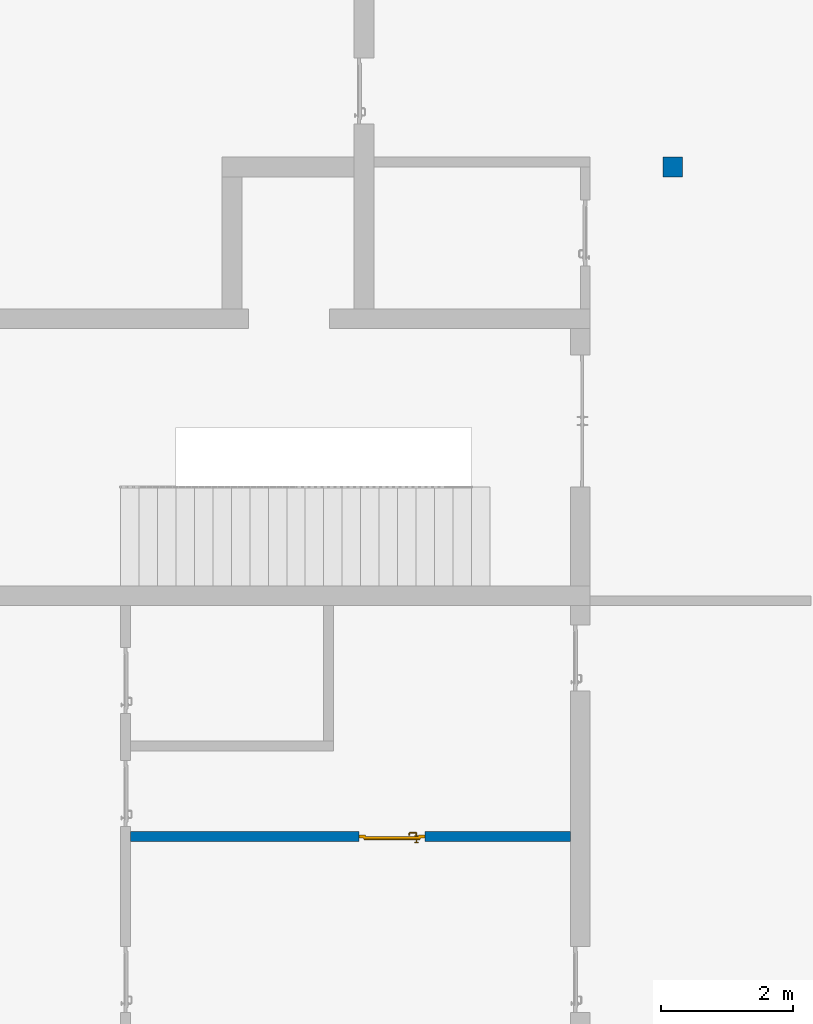
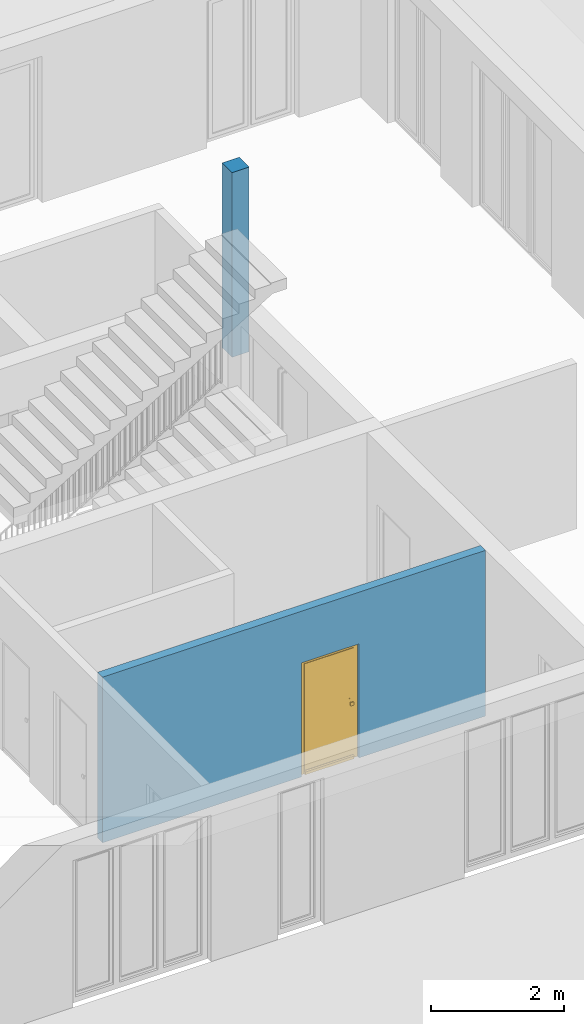
# One storey, part 1 of 23: 1 column, 1 door, 1 wall, 1 opening.
"""IFC4 building model written with IfcOpenShell, lengths in metres."""

from ifc_helpers import new_model, entity, si_unit, converted_unit, derived_unit, direction, frame, origin_with_axes, place, context, subcontext, project, spatial, polygons, source, transform, mapped, material, type_object, element, fill, save


model = new_model("IFC4")

# Units and contexts
model_context = context("Model", 3, precision=1e-05, world=origin_with_axes(), true_north=direction((0.0, 1.0)))
body_context = subcontext(model_context, "Body", "Model", "MODEL_VIEW")
ifc_project = project(units=[si_unit("LENGTHUNIT", "METRE"), si_unit("AREAUNIT", "SQUARE_METRE"), si_unit("VOLUMEUNIT", "CUBIC_METRE"), converted_unit("PLANEANGLEUNIT", "DEGREE", entity("IfcPlaneAngleMeasure", 0.0174532925199), si_unit("PLANEANGLEUNIT", "RADIAN"), dimensions=[0, 0, 0, 0, 0, 0, 0]), converted_unit("TIMEUNIT", "Year", entity("IfcTimeMeasure", 31556926.0), si_unit("TIMEUNIT", "SECOND"), dimensions=[0, 0, 1, 0, 0, 0, 0]), si_unit("MASSUNIT", "GRAM", prefix="KILO"), si_unit("THERMODYNAMICTEMPERATUREUNIT", "DEGREE_CELSIUS"), si_unit("LUMINOUSINTENSITYUNIT", "LUMEN"), si_unit("ENERGYUNIT", "JOULE", prefix="MEGA"), derived_unit("THERMALCONDUCTANCEUNIT", [(si_unit("POWERUNIT", "WATT"), 1), (si_unit("LENGTHUNIT", "METRE"), -1), (si_unit("THERMODYNAMICTEMPERATUREUNIT", "KELVIN"), -1)]), derived_unit("SPECIFICHEATCAPACITYUNIT", [(si_unit("ENERGYUNIT", "JOULE"), 1), (si_unit("MASSUNIT", "GRAM", prefix="KILO"), -1), (si_unit("THERMODYNAMICTEMPERATUREUNIT", "KELVIN"), -1)]), derived_unit("MASSDENSITYUNIT", [(si_unit("MASSUNIT", "GRAM", prefix="KILO"), 1), (si_unit("VOLUMEUNIT", "CUBIC_METRE"), -1)])], contexts=[model_context])

# Site, building, storey
site_placement = place(None, origin_with_axes())
site = spatial("IfcSite", under=ifc_project, at=site_placement, CompositionType="ELEMENT")
building_placement = place(site_placement, origin_with_axes())
building = spatial("IfcBuilding", under=site, at=building_placement, CompositionType="ELEMENT")
storey_placement = place(building_placement, origin_with_axes())
storey = spatial("IfcBuildingStorey", under=building, at=storey_placement, Name="0. Geschoss", CompositionType="ELEMENT", Elevation=0.0)

# Column
ifc_material_1 = material(Name="BAUTEILE")
column_type = type_object("IfcColumnType", Name="BAUTEILE 300 x 300", PredefinedType="NOTDEFINED")
column_placement = place(storey_placement, frame((4.0878006196, 3.82118776896, 0.0), z_axis=(0.0, 0.0, 1.0), x_axis=(1.0, 0.0, 0.0)))
element("IfcColumn", 1, at=column_placement, inside=storey, type_object=column_type, material=ifc_material_1, PredefinedType="NOTDEFINED", context=body_context, shape_type="Tessellation", body=[
    polygons([(-0.15, -0.15, 3.4), (-0.15, -0.15, 0.0), (0.15, -0.15, 0.0), (0.15, -0.15, 3.4), (-0.15, 0.15, 3.4), (-0.15, 0.15, 0.0), (0.15, 0.15, 0.0), (0.15, 0.15, 3.4)], [[[1, 2, 3, 4]], [[5, 6, 2, 1]], [[3, 2, 6, 7]], [[4, 3, 7, 8]], [[5, 1, 4, 8]], [[8, 7, 6, 5]]], closed=True),
])

# Wall, opening, door
ifc_material_2 = material()
wall_type = type_object("IfcWallType", Name="150", PredefinedType="NOTDEFINED")
wall_placement = place(storey_placement, frame((2.6878006196, -6.3288122031, 0.0), z_axis=(0.0, 0.0, 1.0), x_axis=(-1.0, 0.0, 0.0)))
wall = element("IfcWall", 2, at=wall_placement, inside=storey, type_object=wall_type, material=ifc_material_2, Name="Wand-002", PredefinedType="NOTDEFINED", context=body_context, shape_type="Tessellation", body=[
    polygons([(3.35473554301, -0.075, 2.1), (3.35473554301, -0.075, 0.0), (6.82, -0.075, 0.0), (6.82, -0.075, 3.05), (0.15, -0.075, 3.05), (0.15, -0.075, 0.0), (2.35473554301, -0.075, 0.0), (2.35473554301, -0.075, 2.1), (3.35473554301, 0.025, 0.0), (3.35473554301, 0.075, 2.1), (3.35473554301, 0.075, 0.0), (6.82, 0.075, 0.0), (6.82, 0.075, 3.05), (0.15, 0.075, 3.05), (0.15, 0.075, 0.0), (2.35473554301, 0.025, 0.0), (2.35473554301, 0.075, 0.0), (2.35473554301, 0.075, 2.1)], [[[1, 2, 3, 4, 5, 6, 7, 8]], [[9, 2, 1, 10, 11]], [[2, 9, 11, 12, 3]], [[4, 3, 12, 13]], [[5, 4, 13, 14]], [[14, 15, 6, 5]], [[16, 7, 6, 15, 17]], [[8, 7, 16, 17, 18]], [[1, 8, 18, 10]], [[12, 11, 10, 18, 17, 15, 14, 13]]], closed=True),
])
opening_placement = place(wall_placement, frame((2.85473554301, 0.0, 0.0), z_axis=(0.0, 0.0, 1.0), x_axis=(1.0, 0.0, 0.0)))
opening = element("IfcOpeningElement", 3, at=opening_placement, cuts=wall, context=body_context, identifier="Reference", shape_type="Tessellation", body=[
    polygons([(-0.5, 0.025, 0.0), (-0.5, 0.025, 2.1), (-0.5, 0.076, 2.1), (-0.5, 0.076, 0.0), (-0.5, -0.076, 0.0), (-0.5, -0.076, 2.1), (0.5, 0.025, 2.1), (0.5, 0.076, 2.1), (0.5, -0.076, 2.1), (0.5, 0.076, 0.0), (0.5, 0.025, 0.0), (0.5, -0.076, 0.0)], [[[1, 2, 3, 4]], [[2, 1, 5, 6]], [[7, 8, 3, 2, 6, 9]], [[8, 10, 4, 3]], [[1, 4, 10, 11, 12, 5]], [[6, 5, 12, 9]], [[7, 11, 10, 8]], [[11, 7, 9, 12]]], closed=True),
])
door_type = type_object("IfcDoorType", Name="Eingang 01 1-Fl 26", OperationType="SINGLE_SWING_RIGHT", PredefinedType="DOOR")
shared_shape = source(origin_with_axes(), body_context, "Body", "Tessellation", [
    polygons([(0.5, -0.05, 0.0), (0.5, -0.03, 0.0), (0.5, -0.03, 2.1), (0.5, -0.05, 2.1), (0.4, -0.05, 0.0), (0.4, -0.03, 0.0), (0.4, -0.03, 2.0), (0.1301, -0.03, 2.0), (0.0001, -0.03, 2.0), (-0.4, -0.03, 2.0), (-0.4, -0.03, 0.0), (-0.5, -0.03, 0.0), (-0.5, -0.03, 2.1), (-0.5, -0.05, 2.1), (-0.5, -0.05, 0.0), (-0.4, -0.05, 0.0), (-0.4, -0.05, 2.0), (0.0001, -0.05, 2.0), (0.1301, -0.05, 2.0), (0.4, -0.05, 2.0)], [[[1, 2, 3, 4]], [[5, 6, 2, 1]], [[2, 6, 7, 8, 9, 10, 11, 12, 13, 3]], [[4, 3, 13, 14]], [[1, 4, 14, 15, 16, 17, 18, 19, 20, 5]], [[20, 7, 6, 5]], [[19, 8, 7, 20]], [[18, 9, 8, 19]], [[17, 10, 9, 18]], [[16, 11, 10, 17]], [[15, 12, 11, 16]], [[14, 13, 12, 15]]], closed=True),
    polygons([(0.5, -0.03, 0.0), (0.5, 0.0, 0.0), (0.5, 0.0, 2.1), (0.5, -0.03, 2.1), (0.43, -0.03, 0.0), (0.43, 0.0, 0.0), (0.43, 0.0, 2.03), (0.1001, 0.0, 2.03), (0.0301, 0.0, 2.03), (-0.43, 0.0, 2.03), (-0.43, 0.0, 0.0), (-0.5, 0.0, 0.0), (-0.5, 0.0, 2.1), (-0.5, -0.03, 2.1), (-0.5, -0.03, 0.0), (-0.43, -0.03, 0.0), (-0.43, -0.03, 2.03), (0.0301, -0.03, 2.03), (0.1001, -0.03, 2.03), (0.43, -0.03, 2.03)], [[[1, 2, 3, 4]], [[5, 6, 2, 1]], [[2, 6, 7, 8, 9, 10, 11, 12, 13, 3]], [[4, 3, 13, 14]], [[1, 4, 14, 15, 16, 17, 18, 19, 20, 5]], [[20, 7, 6, 5]], [[19, 8, 7, 20]], [[18, 9, 8, 19]], [[17, 10, 9, 18]], [[16, 11, 10, 17]], [[15, 12, 11, 16]], [[14, 13, 12, 15]]], closed=True),
    polygons([(0.43, 0.01, 0.0), (-0.43, 0.01, 0.0), (-0.43, 0.01, 2.03), (0.43, 0.01, 2.03), (0.43, -0.03, 0.0), (-0.43, -0.03, 0.0), (-0.43, -0.03, 2.03), (0.43, -0.03, 2.03)], [[[1, 2, 3, 4]], [[2, 1, 5, 6]], [[3, 2, 6, 7]], [[4, 3, 7, 8]], [[1, 4, 8, 5]], [[6, 5, 8, 7]]], closed=True),
    polygons([(0.425, 0.03, 0.0), (-0.425, 0.03, 0.0), (-0.425, 0.03, 0.05), (0.425, 0.03, 0.05), (0.425, 0.01, 0.0), (-0.425, 0.01, 0.0), (-0.425, 0.01, 0.07), (-0.425, 0.015, 0.07), (0.425, 0.015, 0.07), (0.425, 0.01, 0.07)], [[[1, 2, 3, 4]], [[5, 6, 2, 1]], [[2, 6, 7, 8, 3]], [[4, 3, 8, 9]], [[1, 4, 9, 10, 5]], [[10, 7, 6, 5]], [[9, 8, 7, 10]]], closed=True),
    polygons([(-0.3835, -0.04, 1.0733826859), (-0.37, -0.04, 1.077), (-0.37, -0.0399, 1.077), (-0.3835, -0.0399, 1.0733826859), (-0.393382685902, -0.04, 1.0635), (-0.397, -0.04, 1.05), (-0.393382685902, -0.04, 1.0365), (-0.3835, -0.04, 1.0266173141), (-0.37, -0.04, 1.023), (-0.3565, -0.04, 1.0266173141), (-0.346617314098, -0.04, 1.0365), (-0.343, -0.04, 1.05), (-0.346617314098, -0.04, 1.0635), (-0.3565, -0.04, 1.0733826859), (-0.3565, -0.0399, 1.0733826859), (-0.37, -0.0301, 1.077), (-0.3835, -0.0301, 1.0733826859), (-0.393382685902, -0.0399, 1.0635), (-0.397, -0.0399, 1.05), (-0.393382685902, -0.0399, 1.0365), (-0.3835, -0.0399, 1.0266173141), (-0.37, -0.0399, 1.023), (-0.3565, -0.0399, 1.0266173141), (-0.346617314098, -0.0399, 1.0365), (-0.343, -0.0399, 1.05), (-0.346617314098, -0.0399, 1.0635), (-0.3565, -0.0301, 1.0733826859), (-0.37, -0.03, 1.077), (-0.3835, -0.03, 1.0733826859), (-0.393382685902, -0.0301, 1.0635), (-0.397, -0.0301, 1.05), (-0.393382685902, -0.0301, 1.0365), (-0.3835, -0.0301, 1.0266173141), (-0.37, -0.0301, 1.023), (-0.3565, -0.0301, 1.0266173141), (-0.346617314098, -0.0301, 1.0365), (-0.343, -0.0301, 1.05), (-0.346617314098, -0.0301, 1.0635), (-0.3565, -0.03, 1.0733826859), (-0.346617314098, -0.03, 1.0635), (-0.343, -0.03, 1.05), (-0.346617314098, -0.03, 1.0365), (-0.3565, -0.03, 1.0266173141), (-0.37, -0.03, 1.023), (-0.3835, -0.03, 1.0266173141), (-0.393382685902, -0.03, 1.0365), (-0.397, -0.03, 1.05), (-0.393382685902, -0.03, 1.0635)], [[[1, 2, 3, 4]], [[2, 1, 5, 6, 7, 8, 9, 10, 11, 12, 13, 14]], [[2, 14, 15, 3]], [[4, 3, 16, 17]], [[5, 1, 4, 18]], [[6, 5, 18, 19]], [[7, 6, 19, 20]], [[8, 7, 20, 21]], [[9, 8, 21, 22]], [[10, 9, 22, 23]], [[11, 10, 23, 24]], [[12, 11, 24, 25]], [[13, 12, 25, 26]], [[14, 13, 26, 15]], [[3, 15, 27, 16]], [[17, 16, 28, 29]], [[18, 4, 17, 30]], [[19, 18, 30, 31]], [[20, 19, 31, 32]], [[21, 20, 32, 33]], [[22, 21, 33, 34]], [[23, 22, 34, 35]], [[24, 23, 35, 36]], [[25, 24, 36, 37]], [[26, 25, 37, 38]], [[15, 26, 38, 27]], [[16, 27, 39, 28]], [[28, 39, 40, 41, 42, 43, 44, 45, 46, 47, 48, 29]], [[30, 17, 29, 48]], [[31, 30, 48, 47]], [[32, 31, 47, 46]], [[33, 32, 46, 45]], [[34, 33, 45, 44]], [[35, 34, 44, 43]], [[36, 35, 43, 42]], [[37, 36, 42, 41]], [[38, 37, 41, 40]], [[27, 38, 40, 39]]], closed=True),
    polygons([(-0.362532169224, -0.04, 0.959692280177), (-0.365, -0.04, 0.9544), (-0.365, -0.04, 0.952886751346), (-0.346703916638, -0.04, 0.96345), (-0.35655, -0.04, 0.973296083362), (-0.363279754556, -0.04, 0.961639806549), (-0.362532169224, -0.039, 0.959692280177), (-0.365, -0.039, 0.9544), (-0.365, -0.039, 0.952886751346), (-0.365, -0.039, 0.95), (-0.365, -0.039, 0.947113248654), (-0.365, -0.039, 0.941339745962), (-0.365, -0.039, 0.9375), (-0.365, -0.04, 0.9375), (-0.365, -0.04, 0.941339745962), (-0.365, -0.04, 0.947113248654), (-0.365, -0.04, 0.95), (-0.3431, -0.04, 0.95), (-0.346617314098, -0.04, 0.9635), (-0.3565, -0.04, 0.973382685902), (-0.364624817685, -0.04, 0.965143815798), (-0.37, -0.04, 0.9769), (-0.37, -0.04, 0.967425445323), (-0.364624817685, -0.039, 0.965143815798), (-0.363279754556, -0.039, 0.961639806549), (-0.35705, -0.039, 0.972430057958), (-0.347569942042, -0.039, 0.96295), (-0.3441, -0.039, 0.95), (-0.347569942042, -0.039, 0.93705), (-0.35705, -0.039, 0.927569942042), (-0.37, -0.039, 0.9241), (-0.37, -0.039, 0.9325), (-0.366464466094, -0.039, 0.933964466094), (-0.366464466094, -0.04, 0.933964466094), (-0.35655, -0.04, 0.926703916638), (-0.37, -0.04, 0.9325), (-0.37, -0.04, 0.9231), (-0.346703916638, -0.04, 0.93655), (-0.343, -0.04, 0.95), (-0.346617314098, -0.0399, 0.9635), (-0.3565, -0.0399, 0.973382685902), (-0.37, -0.04, 0.977), (-0.375375182315, -0.04, 0.965143815798), (-0.38345, -0.04, 0.973296083362), (-0.376720245444, -0.04, 0.961639806549), (-0.37, -0.039, 0.967425445323), (-0.37, -0.039, 0.9759), (-0.357, -0.039, 0.972516660498), (-0.347483339502, -0.039, 0.963), (-0.344, -0.039, 0.95), (-0.347483339502, -0.039, 0.937), (-0.357, -0.039, 0.927483339502), (-0.38295, -0.039, 0.927569942042), (-0.375, -0.039, 0.941339745962), (-0.375, -0.039, 0.9375), (-0.373535533906, -0.039, 0.933964466094), (-0.37, -0.039, 0.924), (-0.373535533906, -0.04, 0.933964466094), (-0.375, -0.04, 0.9375), (-0.375, -0.04, 0.941339745962), (-0.38345, -0.04, 0.926703916638), (-0.37, -0.04, 0.923), (-0.3565, -0.04, 0.926617314098), (-0.346617314098, -0.04, 0.9365), (-0.343, -0.0399, 0.95), (-0.346617314098, -0.0301, 0.9635), (-0.3565, -0.0301, 0.973382685902), (-0.37, -0.0399, 0.977), (-0.3835, -0.04, 0.973382685902), (-0.375375182315, -0.039, 0.965143815798), (-0.377467830776, -0.04, 0.959692280177), (-0.393296083362, -0.04, 0.96345), (-0.375, -0.04, 0.952886751346), (-0.375, -0.04, 0.9544), (-0.377467830776, -0.039, 0.959692280177), (-0.376720245444, -0.039, 0.961639806549), (-0.38295, -0.039, 0.972430057958), (-0.37, -0.039, 0.976), (-0.357, -0.0389, 0.972516660498), (-0.347483339502, -0.0389, 0.963), (-0.344, -0.0389, 0.95), (-0.347483339502, -0.0389, 0.937), (-0.357, -0.0389, 0.927483339502), (-0.392430057958, -0.039, 0.93705), (-0.375, -0.039, 0.947113248654), (-0.375, -0.039, 0.9544), (-0.375, -0.04, 0.95), (-0.375, -0.04, 0.947113248654), (-0.375, -0.039, 0.95), (-0.375, -0.039, 0.952886751346), (-0.383, -0.039, 0.927483339502), (-0.37, -0.0389, 0.924), (-0.393296083362, -0.04, 0.93655), (-0.3835, -0.04, 0.926617314098), (-0.37, -0.0399, 0.923), (-0.3565, -0.0399, 0.926617314098), (-0.346617314098, -0.0399, 0.9365), (-0.343, -0.0301, 0.95), (-0.346617314098, -0.03, 0.9635), (-0.3565, -0.03, 0.973382685902), (-0.37, -0.0301, 0.977), (-0.3835, -0.0399, 0.973382685902), (-0.393382685902, -0.04, 0.9635), (-0.3969, -0.04, 0.95), (-0.392430057958, -0.039, 0.96295), (-0.383, -0.039, 0.972516660498), (-0.37, -0.0389, 0.976), (-0.357, -0.0301, 0.972516660498), (-0.347483339502, -0.0301, 0.963), (-0.344, -0.0301, 0.95), (-0.347483339502, -0.0301, 0.937), (-0.357, -0.0301, 0.927483339502), (-0.392516660498, -0.039, 0.937), (-0.3959, -0.039, 0.95), (-0.383, -0.0389, 0.927483339502), (-0.37, -0.0301, 0.924), (-0.393382685902, -0.04, 0.9365), (-0.3835, -0.0399, 0.926617314098), (-0.37, -0.0301, 0.923), (-0.3565, -0.0301, 0.926617314098), (-0.346617314098, -0.0301, 0.9365), (-0.343, -0.03, 0.95), (-0.346703916638, -0.03, 0.96345), (-0.35655, -0.03, 0.973296083362), (-0.37, -0.03, 0.977), (-0.3835, -0.0301, 0.973382685902), (-0.393382685902, -0.0399, 0.9635), (-0.397, -0.04, 0.95), (-0.392516660498, -0.039, 0.963), (-0.383, -0.0389, 0.972516660498), (-0.37, -0.0301, 0.976), (-0.357, -0.03, 0.972516660498), (-0.347483339502, -0.03, 0.963), (-0.344, -0.03, 0.95), (-0.347483339502, -0.03, 0.937), (-0.357, -0.03, 0.927483339502), (-0.392516660498, -0.0389, 0.937), (-0.396, -0.039, 0.95), (-0.383, -0.0301, 0.927483339502), (-0.37, -0.03, 0.924), (-0.393382685902, -0.0399, 0.9365), (-0.3835, -0.0301, 0.926617314098), (-0.37, -0.03, 0.923), (-0.3565, -0.03, 0.926617314098), (-0.346617314098, -0.03, 0.9365), (-0.3431, -0.03, 0.95), (-0.347396736961, -0.03, 0.96305), (-0.35695, -0.03, 0.972603263039), (-0.37, -0.03, 0.9769), (-0.3835, -0.03, 0.973382685902), (-0.393382685902, -0.0301, 0.9635), (-0.397, -0.0399, 0.95), (-0.392516660498, -0.0389, 0.963), (-0.383, -0.0301, 0.972516660498), (-0.37, -0.03, 0.976), (-0.3439, -0.03, 0.95), (-0.347396736961, -0.03, 0.93695), (-0.35695, -0.03, 0.927396736961), (-0.392516660498, -0.0301, 0.937), (-0.396, -0.0389, 0.95), (-0.383, -0.03, 0.927483339502), (-0.37, -0.03, 0.9239), (-0.393382685902, -0.0301, 0.9365), (-0.3835, -0.03, 0.926617314098), (-0.37, -0.03, 0.9231), (-0.35655, -0.03, 0.926703916638), (-0.346703916638, -0.03, 0.93655), (-0.37, -0.03, 0.9761), (-0.38345, -0.03, 0.973296083362), (-0.393382685902, -0.03, 0.9635), (-0.397, -0.0301, 0.95), (-0.392516660498, -0.0301, 0.963), (-0.383, -0.03, 0.972516660498), (-0.392516660498, -0.03, 0.937), (-0.396, -0.0301, 0.95), (-0.38305, -0.03, 0.927396736961), (-0.393382685902, -0.03, 0.9365), (-0.38345, -0.03, 0.926703916638), (-0.38305, -0.03, 0.972603263039), (-0.393296083362, -0.03, 0.96345), (-0.397, -0.03, 0.95), (-0.392516660498, -0.03, 0.963), (-0.392603263039, -0.03, 0.93695), (-0.396, -0.03, 0.95), (-0.393296083362, -0.03, 0.93655), (-0.392603263039, -0.03, 0.96305), (-0.3969, -0.03, 0.95), (-0.3961, -0.03, 0.95)], [[[1, 2, 3, 4, 5, 6]], [[2, 1, 7, 8]], [[2, 8, 9, 10, 11, 12, 13, 14, 15, 16, 17, 3]], [[17, 18, 4, 3]], [[19, 20, 5, 4]], [[21, 6, 5, 22, 23]], [[1, 6, 21, 24, 25, 7]], [[7, 25, 26, 27, 9, 8]], [[9, 27, 28, 10]], [[10, 28, 29, 11]], [[11, 29, 30, 12]], [[31, 32, 33, 13, 12, 30]], [[14, 13, 33, 34]], [[35, 15, 14, 34, 36, 37]], [[15, 35, 38, 16]], [[16, 38, 18, 17]], [[39, 19, 4, 18]], [[40, 41, 20, 19]], [[20, 42, 22, 5]], [[43, 23, 22, 44, 45]], [[21, 23, 46, 24]], [[24, 46, 47, 26, 25]], [[27, 26, 48, 49]], [[28, 27, 49, 50]], [[29, 28, 50, 51]], [[30, 29, 51, 52]], [[53, 54, 55, 56, 32, 31]], [[34, 33, 32, 36]], [[31, 30, 52, 57]], [[37, 36, 58, 59, 60, 61]], [[62, 63, 35, 37]], [[63, 64, 38, 35]], [[64, 39, 18, 38]], [[65, 40, 19, 39]], [[66, 67, 41, 40]], [[41, 68, 42, 20]], [[42, 69, 44, 22]], [[23, 43, 70, 46]], [[71, 45, 44, 72, 73, 74]], [[43, 45, 71, 75, 76, 70]], [[70, 76, 77, 47, 46]], [[26, 47, 78, 48]], [[49, 48, 79, 80]], [[50, 49, 80, 81]], [[51, 50, 81, 82]], [[52, 51, 82, 83]], [[54, 53, 84, 85]], [[86, 74, 73, 87, 88, 60, 59, 55, 54, 85, 89, 90]], [[58, 56, 55, 59]], [[36, 32, 56, 58]], [[53, 31, 57, 91]], [[57, 52, 83, 92]], [[88, 93, 61, 60]], [[94, 62, 37, 61]], [[95, 96, 63, 62]], [[96, 97, 64, 63]], [[97, 65, 39, 64]], [[98, 66, 40, 65]], [[99, 100, 67, 66]], [[67, 101, 68, 41]], [[68, 102, 69, 42]], [[69, 103, 72, 44]], [[73, 72, 104, 87]], [[71, 74, 86, 75]], [[75, 86, 90, 105, 77, 76]], [[47, 77, 106, 78]], [[48, 78, 107, 79]], [[80, 79, 108, 109]], [[81, 80, 109, 110]], [[82, 81, 110, 111]], [[83, 82, 111, 112]], [[84, 53, 91, 113]], [[85, 84, 114, 89]], [[87, 104, 93, 88]], [[89, 114, 105, 90]], [[91, 57, 92, 115]], [[92, 83, 112, 116]], [[117, 94, 61, 93]], [[118, 95, 62, 94]], [[119, 120, 96, 95]], [[120, 121, 97, 96]], [[121, 98, 65, 97]], [[122, 99, 66, 98]], [[123, 124, 100, 99]], [[100, 125, 101, 67]], [[101, 126, 102, 68]], [[102, 127, 103, 69]], [[103, 128, 104, 72]], [[77, 105, 129, 106]], [[78, 106, 130, 107]], [[79, 107, 131, 108]], [[109, 108, 132, 133]], [[110, 109, 133, 134]], [[111, 110, 134, 135]], [[112, 111, 135, 136]], [[113, 91, 115, 137]], [[114, 84, 113, 138]], [[128, 117, 93, 104]], [[105, 114, 138, 129]], [[115, 92, 116, 139]], [[116, 112, 136, 140]], [[141, 118, 94, 117]], [[142, 119, 95, 118]], [[143, 144, 120, 119]], [[144, 145, 121, 120]], [[145, 122, 98, 121]], [[146, 123, 99, 122]], [[147, 148, 124, 123]], [[124, 149, 125, 100]], [[125, 150, 126, 101]], [[126, 151, 127, 102]], [[127, 152, 128, 103]], [[106, 129, 153, 130]], [[107, 130, 154, 131]], [[108, 131, 155, 132]], [[133, 132, 148, 147]], [[134, 133, 147, 156]], [[135, 134, 156, 157]], [[136, 135, 157, 158]], [[137, 115, 139, 159]], [[138, 113, 137, 160]], [[152, 141, 117, 128]], [[129, 138, 160, 153]], [[139, 116, 140, 161]], [[140, 136, 158, 162]], [[163, 142, 118, 141]], [[164, 143, 119, 142]], [[165, 166, 144, 143]], [[166, 167, 145, 144]], [[167, 146, 122, 145]], [[156, 147, 123, 146]], [[148, 168, 149, 124]], [[149, 169, 150, 125]], [[150, 170, 151, 126]], [[151, 171, 152, 127]], [[130, 153, 172, 154]], [[131, 154, 173, 155]], [[132, 155, 168, 148]], [[157, 156, 146, 167]], [[158, 157, 167, 166]], [[159, 139, 161, 174]], [[160, 137, 159, 175]], [[171, 163, 141, 152]], [[153, 160, 175, 172]], [[161, 140, 162, 176]], [[162, 158, 166, 165]], [[177, 164, 142, 163]], [[178, 165, 143, 164]], [[168, 179, 169, 149]], [[169, 180, 170, 150]], [[170, 181, 171, 151]], [[154, 172, 182, 173]], [[155, 173, 179, 168]], [[174, 161, 176, 183]], [[175, 159, 174, 184]], [[181, 177, 163, 171]], [[172, 175, 184, 182]], [[176, 162, 165, 178]], [[185, 178, 164, 177]], [[179, 186, 180, 169]], [[180, 187, 181, 170]], [[173, 182, 186, 179]], [[183, 176, 178, 185]], [[184, 174, 183, 188]], [[187, 185, 177, 181]], [[182, 184, 188, 186]], [[186, 188, 187, 180]], [[188, 183, 185, 187]]], closed=True),
    polygons([(-0.38, -0.04, 1.05), (-0.377071067812, -0.04, 1.04292893219), (-0.377071067812, -0.070696439392, 1.04292893219), (-0.38, -0.0709849140336, 1.05), (-0.37, -0.04, 1.04), (-0.37, -0.07, 1.04), (-0.375518993221, -0.0784992452783, 1.04292893219), (-0.378277987014, -0.0796420579258, 1.05), (-0.377071067812, -0.04, 1.05707106781), (-0.377071067812, -0.070696439392, 1.05707106781), (-0.362928932188, -0.04, 1.04292893219), (-0.362928932188, -0.069303560608, 1.04292893219), (-0.368858192988, -0.0757402514855, 1.04), (-0.370704557509, -0.0857045575088, 1.04292893219), (-0.372816199938, -0.0878161999379, 1.05), (-0.375518993221, -0.0784992452783, 1.05707106781), (-0.37, -0.04, 1.06), (-0.37, -0.07, 1.06), (-0.36, -0.04, 1.05), (-0.36, -0.0690150859664, 1.05), (-0.362197392755, -0.0729812576926, 1.04292893219), (-0.365606601718, -0.0806066017178, 1.04), (-0.363499245278, -0.0905189932208, 1.04292893219), (-0.364642057926, -0.0932779870137, 1.05), (-0.370704557509, -0.0857045575088, 1.05707106781), (-0.368858192988, -0.0757402514855, 1.06), (-0.362928932188, -0.04, 1.05707106781), (-0.362928932188, -0.069303560608, 1.05707106781), (-0.359438398962, -0.0718384450452, 1.05), (-0.360508645927, -0.0755086459268, 1.04292893219), (-0.360740251485, -0.0838581929877, 1.04), (-0.355696439392, -0.0920710678119, 1.04292893219), (-0.355984914034, -0.095, 1.05), (-0.363499245278, -0.0905189932208, 1.05707106781), (-0.365606601718, -0.0806066017178, 1.06), (-0.362197392755, -0.0729812576926, 1.05707106781), (-0.358397003498, -0.0733970034977, 1.05), (-0.357981257693, -0.0771973927545, 1.04292893219), (-0.355, -0.085, 1.04), (-0.274303560608, -0.0920710678119, 1.04292893219), (-0.274015085966, -0.095, 1.05), (-0.355696439392, -0.0920710678119, 1.05707106781), (-0.360740251485, -0.0838581929877, 1.06), (-0.360508645927, -0.0755086459268, 1.05707106781), (-0.356838445045, -0.0744383989617, 1.05), (-0.354303560608, -0.0779289321881, 1.04292893219), (-0.275, -0.085, 1.04), (-0.266500754722, -0.0905189932208, 1.04292893219), (-0.265357942074, -0.0932779870137, 1.05), (-0.274303560608, -0.0920710678119, 1.05707106781), (-0.355, -0.085, 1.06), (-0.357981257693, -0.0771973927545, 1.05707106781), (-0.354015085966, -0.075, 1.05), (-0.275696439392, -0.0779289321881, 1.04292893219), (-0.269259748515, -0.0838581929877, 1.04), (-0.259295442491, -0.0857045575088, 1.04292893219), (-0.257183800062, -0.0878161999379, 1.05), (-0.266500754722, -0.0905189932208, 1.05707106781), (-0.275, -0.085, 1.06), (-0.354303560608, -0.0779289321881, 1.05707106781), (-0.275984914034, -0.075, 1.05), (-0.272018742307, -0.0771973927545, 1.04292893219), (-0.264393398282, -0.0806066017178, 1.04), (-0.254481006779, -0.0784992452783, 1.04292893219), (-0.251722012986, -0.0796420579258, 1.05), (-0.259295442491, -0.0857045575088, 1.05707106781), (-0.269259748515, -0.0838581929877, 1.06), (-0.275696439392, -0.0779289321881, 1.05707106781), (-0.273161554955, -0.0744383989617, 1.05), (-0.269491354073, -0.0755086459268, 1.04292893219), (-0.261141807012, -0.0757402514855, 1.04), (-0.252928932188, -0.070696439392, 1.04292893219), (-0.25, -0.0709849140336, 1.05), (-0.254481006779, -0.0784992452783, 1.05707106781), (-0.264393398282, -0.0806066017178, 1.06), (-0.272018742307, -0.0771973927545, 1.05707106781), (-0.271602996502, -0.0733970034977, 1.05), (-0.267802607245, -0.0729812576926, 1.04292893219), (-0.26, -0.07, 1.04), (-0.252928932188, -0.04, 1.04292893219), (-0.25, -0.04, 1.05), (-0.252928932188, -0.070696439392, 1.05707106781), (-0.261141807012, -0.0757402514855, 1.06), (-0.269491354073, -0.0755086459268, 1.05707106781), (-0.270561601038, -0.0718384450452, 1.05), (-0.267071067812, -0.069303560608, 1.04292893219), (-0.26, -0.04, 1.04), (-0.267071067812, -0.04, 1.04292893219), (-0.27, -0.04, 1.05), (-0.267071067812, -0.04, 1.05707106781), (-0.26, -0.04, 1.06), (-0.252928932188, -0.04, 1.05707106781), (-0.26, -0.07, 1.06), (-0.267802607245, -0.0729812576926, 1.05707106781), (-0.27, -0.0690150859664, 1.05), (-0.267071067812, -0.069303560608, 1.05707106781)], [[[1, 2, 3, 4]], [[2, 5, 6, 3]], [[4, 3, 7, 8]], [[9, 1, 4, 10]], [[5, 11, 12, 6]], [[3, 6, 13, 7]], [[8, 7, 14, 15]], [[10, 4, 8, 16]], [[17, 9, 10, 18]], [[11, 19, 20, 12]], [[6, 12, 21, 13]], [[7, 13, 22, 14]], [[15, 14, 23, 24]], [[16, 8, 15, 25]], [[18, 10, 16, 26]], [[27, 17, 18, 28]], [[19, 27, 28, 20]], [[12, 20, 29, 21]], [[13, 21, 30, 22]], [[14, 22, 31, 23]], [[24, 23, 32, 33]], [[25, 15, 24, 34]], [[26, 16, 25, 35]], [[28, 18, 26, 36]], [[20, 28, 36, 29]], [[21, 29, 37, 30]], [[22, 30, 38, 31]], [[23, 31, 39, 32]], [[33, 32, 40, 41]], [[34, 24, 33, 42]], [[35, 25, 34, 43]], [[36, 26, 35, 44]], [[29, 36, 44, 37]], [[30, 37, 45, 38]], [[31, 38, 46, 39]], [[32, 39, 47, 40]], [[41, 40, 48, 49]], [[42, 33, 41, 50]], [[43, 34, 42, 51]], [[44, 35, 43, 52]], [[37, 44, 52, 45]], [[38, 45, 53, 46]], [[39, 46, 54, 47]], [[40, 47, 55, 48]], [[49, 48, 56, 57]], [[50, 41, 49, 58]], [[51, 42, 50, 59]], [[52, 43, 51, 60]], [[45, 52, 60, 53]], [[46, 53, 61, 54]], [[47, 54, 62, 55]], [[48, 55, 63, 56]], [[57, 56, 64, 65]], [[58, 49, 57, 66]], [[59, 50, 58, 67]], [[60, 51, 59, 68]], [[53, 60, 68, 61]], [[54, 61, 69, 62]], [[55, 62, 70, 63]], [[56, 63, 71, 64]], [[65, 64, 72, 73]], [[66, 57, 65, 74]], [[67, 58, 66, 75]], [[68, 59, 67, 76]], [[61, 68, 76, 69]], [[62, 69, 77, 70]], [[63, 70, 78, 71]], [[64, 71, 79, 72]], [[73, 72, 80, 81]], [[74, 65, 73, 82]], [[75, 66, 74, 83]], [[76, 67, 75, 84]], [[69, 76, 84, 77]], [[70, 77, 85, 78]], [[71, 78, 86, 79]], [[72, 79, 87, 80]], [[81, 80, 87, 88, 89, 90, 91, 92]], [[82, 73, 81, 92]], [[83, 74, 82, 93]], [[84, 75, 83, 94]], [[77, 84, 94, 85]], [[78, 85, 95, 86]], [[79, 86, 88, 87]], [[86, 95, 89, 88]], [[95, 96, 90, 89]], [[96, 93, 91, 90]], [[93, 82, 92, 91]], [[94, 83, 93, 96]], [[85, 94, 96, 95]]], closed=False),
    polygons([(-0.364696699141, 0.015, 1.04469669914), (-0.3625, 0.015, 1.05), (-0.364696699141, 0.015, 1.05530330086), (-0.37, 0.015, 1.0575), (-0.375303300859, 0.015, 1.05530330086), (-0.3775, 0.015, 1.05), (-0.375303300859, 0.015, 1.04469669914), (-0.37, 0.015, 1.0425), (-0.364696699141, 0.055, 1.04469669914), (-0.3625, 0.055, 1.05), (-0.364696699141, 0.055, 1.05530330086), (-0.37, 0.055, 1.0575), (-0.375303300859, 0.055, 1.05530330086), (-0.3775, 0.055, 1.05), (-0.375303300859, 0.055, 1.04469669914), (-0.37, 0.055, 1.0425)], [[[1, 2, 3, 4, 5, 6, 7, 8]], [[1, 9, 10, 2]], [[2, 10, 11, 3]], [[3, 11, 12, 4]], [[4, 12, 13, 5]], [[5, 13, 14, 6]], [[6, 14, 15, 7]], [[7, 15, 16, 8]], [[8, 16, 9, 1]], [[9, 16, 15, 14, 13, 12, 11, 10]]], closed=True),
    polygons([(-0.395, 0.01, 0.975), (-0.395, 0.015, 0.975), (-0.393096988313, 0.015, 0.965432914191), (-0.393096988313, 0.01, 0.965432914191), (-0.395, 0.01, 1.1), (-0.395, 0.015, 1.1), (-0.393096988313, 0.015, 1.10956708581), (-0.38767766953, 0.015, 1.11767766953), (-0.379567085809, 0.015, 1.12309698831), (-0.37, 0.015, 1.125), (-0.360432914191, 0.015, 1.12309698831), (-0.35232233047, 0.015, 1.11767766953), (-0.346903011687, 0.015, 1.10956708581), (-0.345, 0.015, 1.1), (-0.345, 0.015, 0.975), (-0.346903011687, 0.015, 0.965432914191), (-0.35232233047, 0.015, 0.95732233047), (-0.360432914191, 0.015, 0.951903011687), (-0.37, 0.015, 0.95), (-0.379567085809, 0.015, 0.951903011687), (-0.38767766953, 0.015, 0.95732233047), (-0.38767766953, 0.01, 0.95732233047), (-0.379567085809, 0.01, 0.951903011687), (-0.37, 0.01, 0.95), (-0.360432914191, 0.01, 0.951903011687), (-0.35232233047, 0.01, 0.95732233047), (-0.346903011687, 0.01, 0.965432914191), (-0.345, 0.01, 0.975), (-0.345, 0.01, 1.1), (-0.346903011687, 0.01, 1.10956708581), (-0.35232233047, 0.01, 1.11767766953), (-0.360432914191, 0.01, 1.12309698831), (-0.37, 0.01, 1.125), (-0.379567085809, 0.01, 1.12309698831), (-0.38767766953, 0.01, 1.11767766953), (-0.393096988313, 0.01, 1.10956708581)], [[[1, 2, 3, 4]], [[5, 6, 2, 1]], [[2, 6, 7, 8, 9, 10, 11, 12, 13, 14, 15, 16, 17, 18, 19, 20, 21, 3]], [[4, 3, 21, 22]], [[1, 4, 22, 23, 24, 25, 26, 27, 28, 29, 30, 31, 32, 33, 34, 35, 36, 5]], [[36, 7, 6, 5]], [[35, 8, 7, 36]], [[34, 9, 8, 35]], [[33, 10, 9, 34]], [[32, 11, 10, 33]], [[31, 12, 11, 32]], [[30, 13, 12, 31]], [[29, 14, 13, 30]], [[28, 15, 14, 29]], [[27, 16, 15, 28]], [[26, 17, 16, 27]], [[25, 18, 17, 26]], [[24, 19, 18, 25]], [[23, 20, 19, 24]], [[22, 21, 20, 23]]], closed=True),
    polygons([(-0.39, 0.055, 1.08), (-0.39, 0.07, 1.08), (-0.395, 0.07, 1.07866025404), (-0.395, 0.055, 1.07866025404), (-0.35, 0.055, 1.08), (-0.35, 0.07, 1.08), (-0.345, 0.07, 1.07866025404), (-0.341339745962, 0.07, 1.075), (-0.34, 0.07, 1.07), (-0.34, 0.07, 1.03), (-0.341339745962, 0.07, 1.025), (-0.345, 0.07, 1.02133974596), (-0.35, 0.07, 1.02), (-0.39, 0.07, 1.02), (-0.395, 0.07, 1.02133974596), (-0.398660254038, 0.07, 1.025), (-0.4, 0.07, 1.03), (-0.4, 0.07, 1.07), (-0.398660254038, 0.07, 1.075), (-0.398660254038, 0.055, 1.075), (-0.4, 0.055, 1.07), (-0.4, 0.055, 1.03), (-0.398660254038, 0.055, 1.025), (-0.395, 0.055, 1.02133974596), (-0.39, 0.055, 1.02), (-0.35, 0.055, 1.02), (-0.345, 0.055, 1.02133974596), (-0.341339745962, 0.055, 1.025), (-0.34, 0.055, 1.03), (-0.34, 0.055, 1.07), (-0.341339745962, 0.055, 1.075), (-0.345, 0.055, 1.07866025404)], [[[1, 2, 3, 4]], [[5, 6, 2, 1]], [[2, 6, 7, 8, 9, 10, 11, 12, 13, 14, 15, 16, 17, 18, 19, 3]], [[4, 3, 19, 20]], [[1, 4, 20, 21, 22, 23, 24, 25, 26, 27, 28, 29, 30, 31, 32, 5]], [[32, 7, 6, 5]], [[31, 8, 7, 32]], [[30, 9, 8, 31]], [[29, 10, 9, 30]], [[28, 11, 10, 29]], [[27, 12, 11, 28]], [[26, 13, 12, 27]], [[25, 14, 13, 26]], [[24, 15, 14, 25]], [[23, 16, 15, 24]], [[22, 17, 16, 23]], [[21, 18, 17, 22]], [[20, 19, 18, 21]]], closed=True),
])
door_placement = place(opening_placement, frame((-0.4, 0.0, 0.0), z_axis=(0.0, 0.0, 1.0), x_axis=(1.0, 0.0, 0.0)))
door = element("IfcDoor", 4, at=door_placement, inside=storey, type_object=door_type, OverallHeight=2.1, OverallWidth=1.0, PredefinedType="DOOR", context=body_context, shape_type="MappedRepresentation", body=[
    mapped(shared_shape, transform((0.4, 0.025, 0.0))),
])
fill(opening, door)

save(model, "model.ifc")
